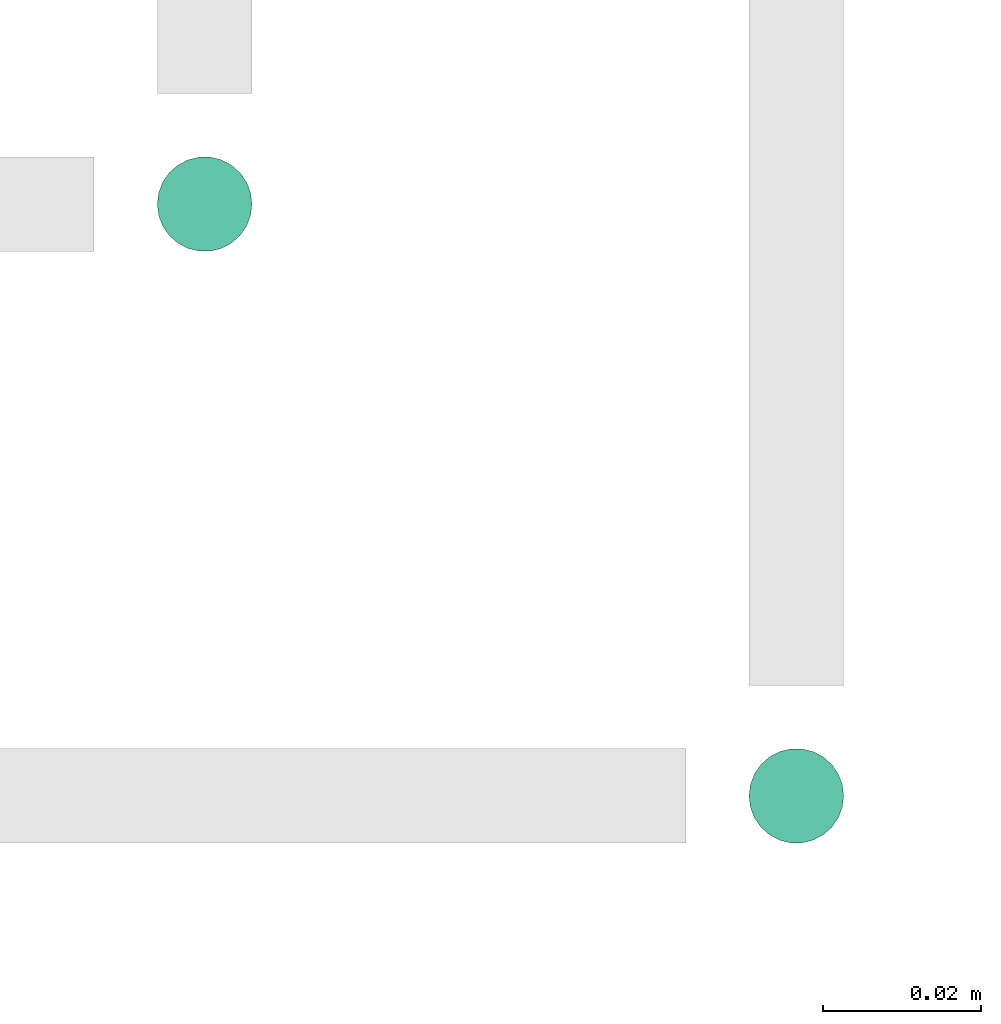
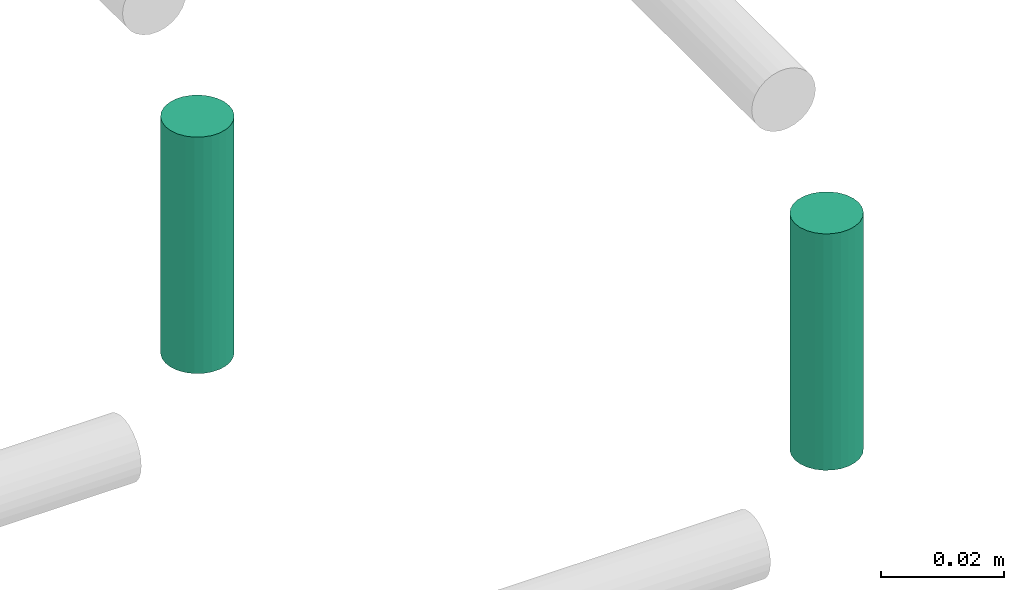
# One storey, part 307 of 331: 2 flow segments.
"""IFC2X3 building model written with IfcOpenShell, lengths in millimetres."""

from ifc_helpers import new_model, entity, si_unit, converted_unit, derived_unit, direction, frame, frame_2d, origin, origin_2d_with_axis, place, context, subcontext, project, spatial, circle, extrude, type_object, element, save


model = new_model("IFC2X3")

# Units and contexts
model_context = context("Model", 3, precision=0.01, world=origin(), true_north=direction((6.12303176911189e-17, 1.0)))
body_context = subcontext(model_context, "Body", "Model", "MODEL_VIEW")
ifc_project = project(units=[si_unit("LENGTHUNIT", "METRE", prefix="MILLI"), si_unit("AREAUNIT", "SQUARE_METRE"), si_unit("VOLUMEUNIT", "CUBIC_METRE"), converted_unit("PLANEANGLEUNIT", "DEGREE", entity("IfcRatioMeasure", 0.0174532925199433), si_unit("PLANEANGLEUNIT", "RADIAN"), dimensions=[0, 0, 0, 0, 0, 0, 0]), si_unit("MASSUNIT", "GRAM", prefix="KILO"), derived_unit("MASSDENSITYUNIT", [(si_unit("MASSUNIT", "GRAM", prefix="KILO"), 1), (si_unit("LENGTHUNIT", "METRE"), -3)]), derived_unit("MOMENTOFINERTIAUNIT", [(si_unit("LENGTHUNIT", "METRE"), 4)]), si_unit("TIMEUNIT", "SECOND"), si_unit("FREQUENCYUNIT", "HERTZ"), si_unit("THERMODYNAMICTEMPERATUREUNIT", "DEGREE_CELSIUS"), derived_unit("THERMALTRANSMITTANCEUNIT", [(si_unit("MASSUNIT", "GRAM", prefix="KILO"), 1), (si_unit("THERMODYNAMICTEMPERATUREUNIT", "KELVIN"), -1), (si_unit("TIMEUNIT", "SECOND"), -3)]), derived_unit("VOLUMETRICFLOWRATEUNIT", [(si_unit("LENGTHUNIT", "METRE"), 3), (si_unit("TIMEUNIT", "SECOND"), -1)]), derived_unit("MASSFLOWRATEUNIT", [(si_unit("MASSUNIT", "GRAM", prefix="KILO"), 1), (si_unit("TIMEUNIT", "SECOND"), -1)]), derived_unit("ROTATIONALFREQUENCYUNIT", [(si_unit("TIMEUNIT", "SECOND"), -1)]), si_unit("ELECTRICCURRENTUNIT", "AMPERE"), si_unit("ELECTRICVOLTAGEUNIT", "VOLT"), si_unit("POWERUNIT", "WATT"), si_unit("FORCEUNIT", "NEWTON", prefix="KILO"), si_unit("ILLUMINANCEUNIT", "LUX"), si_unit("LUMINOUSFLUXUNIT", "LUMEN"), si_unit("LUMINOUSINTENSITYUNIT", "CANDELA"), derived_unit("USERDEFINED", [(si_unit("MASSUNIT", "GRAM", prefix="KILO"), -1), (si_unit("LENGTHUNIT", "METRE"), -2), (si_unit("TIMEUNIT", "SECOND"), 3), (si_unit("LUMINOUSFLUXUNIT", "LUMEN"), 1)]), derived_unit("LINEARVELOCITYUNIT", [(si_unit("LENGTHUNIT", "METRE"), 1), (si_unit("TIMEUNIT", "SECOND"), -1)]), si_unit("PRESSUREUNIT", "PASCAL"), derived_unit("USERDEFINED", [(si_unit("LENGTHUNIT", "METRE"), -2), (si_unit("MASSUNIT", "GRAM", prefix="KILO"), 1), (si_unit("TIMEUNIT", "SECOND"), -2)]), derived_unit("LINEARFORCEUNIT", [(si_unit("MASSUNIT", "GRAM", prefix="KILO"), 1), (si_unit("LENGTHUNIT", "METRE"), 1), (si_unit("TIMEUNIT", "SECOND"), -2), (si_unit("LENGTHUNIT", "METRE"), -1)]), derived_unit("PLANARFORCEUNIT", [(si_unit("MASSUNIT", "GRAM", prefix="KILO"), 1), (si_unit("LENGTHUNIT", "METRE"), 1), (si_unit("TIMEUNIT", "SECOND"), -2), (si_unit("LENGTHUNIT", "METRE"), -2)])], contexts=[model_context])

# Site, building, storey
site_placement = place(None, frame((0.0, -0.00077364408347762, 0.0)))
site = spatial("IfcSite", under=ifc_project, at=site_placement, CompositionType="ELEMENT")
building_placement = place(site_placement, origin())
building = spatial("IfcBuilding", under=site, at=building_placement, CompositionType="ELEMENT")
storey_placement = place(building_placement, origin())
storey = spatial("IfcBuildingStorey", under=building, at=storey_placement, CompositionType="ELEMENT", Elevation=0.0)

# Flow segments
pipe_segment_type = type_object("IfcPipeSegmentType", PredefinedType="NOTDEFINED")
flow_segment_1_placement = place(building_placement, frame((65002.5100168242, 8290.39243233187, 6689.0)))
element("IfcFlowSegment", 1, at=flow_segment_1_placement, inside=storey, type_object=pipe_segment_type, context=body_context, shape_type="SweptSolid", body=[
    extrude(circle(Radius=6.0, at=frame_2d((0.0, -1.08286712929839e-12), x_axis=(1.0, 0.0))), frame((7.59527223591454, 7.5952722359167, 0.0)), (0.0, 0.0, 1.0), 46.9999999999904),
])
flow_segment_2_placement = place(building_placement, frame((64927.5100168242, 8365.39243233186, 6689.0)))
element("IfcFlowSegment", 2, at=flow_segment_2_placement, inside=storey, type_object=pipe_segment_type, context=body_context, shape_type="SweptSolid", body=[
    extrude(circle(Radius=6.0, at=origin_2d_with_axis()), frame((7.59527223591454, 7.59527223591562, 0.0)), (0.0, 0.0, 1.0), 46.9999999999926),
])

save(model, "model.ifc")
